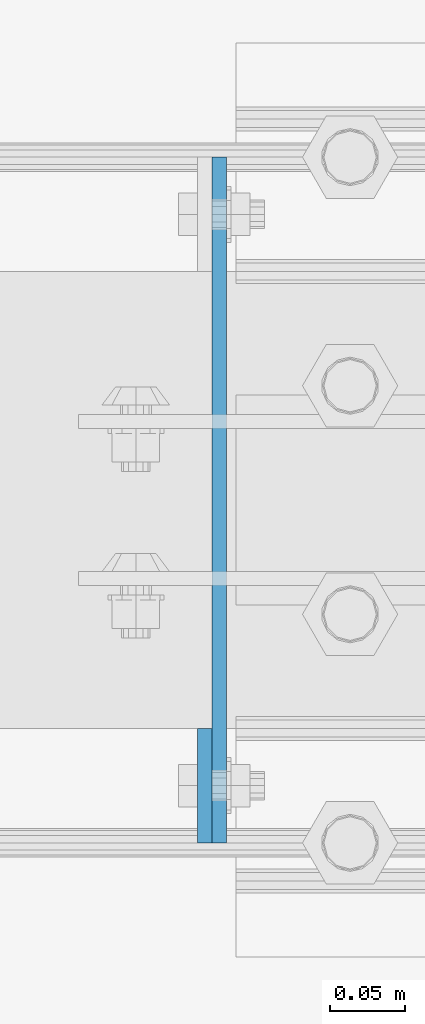
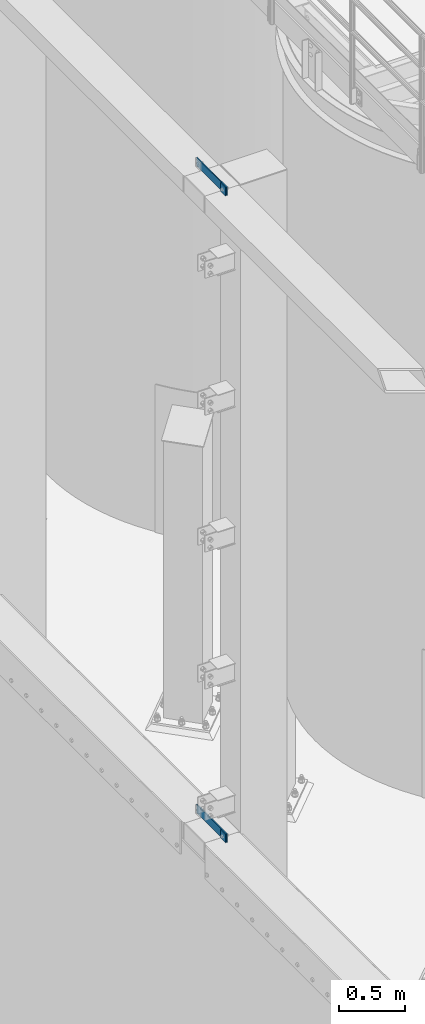
# One storey, part 1411 of 1876: 4 plates, 3 elements without a shape of their own.
"""IFC2X3 building model written with IfcOpenShell, lengths in millimetres."""

from ifc_helpers import new_model, si_unit, frame, origin_with_axes, place, context, subcontext, project, spatial, faceted_brep, material, type_object, element, aggregate, save


model = new_model("IFC2X3")

# Units and contexts
model_context = context("Model", 3, precision=1e-05, world=origin_with_axes())
body_context = subcontext(model_context, "Body", "Model", "MODEL_VIEW")
ifc_project = project(units=[si_unit("LENGTHUNIT", "METRE", prefix="MILLI"), si_unit("AREAUNIT", "SQUARE_METRE"), si_unit("VOLUMEUNIT", "CUBIC_METRE"), si_unit("MASSUNIT", "GRAM", prefix="KILO"), si_unit("TIMEUNIT", "SECOND"), si_unit("PLANEANGLEUNIT", "RADIAN"), si_unit("SOLIDANGLEUNIT", "STERADIAN"), si_unit("THERMODYNAMICTEMPERATUREUNIT", "DEGREE_CELSIUS"), si_unit("LUMINOUSINTENSITYUNIT", "LUMEN")], contexts=[model_context])

# Site, building, storey
site_placement = place(None, origin_with_axes())
site = spatial("IfcSite", under=ifc_project, at=site_placement, CompositionType="ELEMENT")
building_placement = place(site_placement, origin_with_axes())
building = spatial("IfcBuilding", under=site, at=building_placement, Name="Undefined", CompositionType="ELEMENT")
storey_placement = place(building_placement, origin_with_axes())
storey = spatial("IfcBuildingStorey", under=building, at=storey_placement, Name="Undefined", CompositionType="ELEMENT", Elevation=0.0)

# Assembly, plate
assembly_1_placement = place(storey_placement, origin_with_axes())
assembly_1 = element("IfcElementAssembly", 1, at=assembly_1_placement, inside=storey, Name="BEAM", AssemblyPlace="NOTDEFINED", PredefinedType="RIGID_FRAME")
ifc_material = material(Name="STEEL/A36")
plate_type = type_object("IfcPlateType", PredefinedType="NOTDEFINED")
plate_1_placement = place(assembly_1_placement, frame((-144.4625, -18237.2, 10667.9356518697), z_axis=(0.0, -1.0, 0.0), x_axis=(0.0, 0.0, 1.0)))
plate_1 = element("IfcPlate", 2, at=plate_1_placement, type_object=plate_type, material=ifc_material, Name="PLATE", context=body_context, shape_type="Brep", body=[
    faceted_brep([(0.0, -4.76249999999982, 0.0), (0.0643511861562729, -4.76249999999999, 76.1999969482422), (0.0643511861562729, 4.76249999999999, 76.1999969482422), (0.0, 4.76249999999982, 0.0), (76.2643508911133, -4.76249999999999, 76.1999969482422), (76.2643508911133, 4.76249999999999, 76.1999969482422), (76.2643508911133, -4.76249999999999, 0.0), (76.2643508911133, 4.76249999999999, 0.0)], [[[0, 1, 2, 3]], [[1, 4, 5, 2]], [[4, 6, 7, 5]], [[6, 0, 3, 7]], [[5, 7, 3, 2]], [[6, 4, 1, 0]]]),
])
aggregate(assembly_1, [plate_1])

assembly_2_placement = place(storey_placement, origin_with_axes())
assembly_2 = element("IfcElementAssembly", 3, at=assembly_2_placement, inside=storey, Name="COLUMN", AssemblyPlace="NOTDEFINED", PredefinedType="RIGID_FRAME")
plate_2_placement = place(assembly_2_placement, frame((-134.9375, -18313.4, 10744.2), z_axis=(0.0, 1.0, 0.0), x_axis=(0.0, 0.0, -1.0)))
plate_2 = element("IfcPlate", 4, at=plate_2_placement, type_object=plate_type, material=ifc_material, Name="PLATE", context=body_context, shape_type="Brep", body=[
    faceted_brep([(0.0, -4.76249999999982, 0.0), (0.0, -4.76250000000073, 457.200012207031), (0.0, 4.76250000000073, 457.200012207031), (0.0, 4.76249999999982, 0.0), (76.1999969482422, -4.76250000000073, 457.200012207031), (76.1999969482422, 4.76250000000073, 457.200012207031), (76.1999969482422, -4.76250000000073, 0.0), (76.1999969482422, 4.76250000000073, 0.0)], [[[0, 1, 2, 3]], [[1, 4, 5, 2]], [[4, 6, 7, 5]], [[6, 0, 3, 7]], [[5, 7, 3, 2]], [[6, 4, 1, 0]]]),
])

assembly_3_placement = place(storey_placement, origin_with_axes())
assembly_3 = element("IfcElementAssembly", 5, at=assembly_3_placement, inside=storey, Name="BEAM", AssemblyPlace="NOTDEFINED", PredefinedType="RIGID_FRAME")
plate_3_placement = place(assembly_3_placement, frame((-144.4625, -18237.2, 4673.53565186968), z_axis=(0.0, -1.0, 0.0), x_axis=(0.0, 0.0, 1.0)))
plate_3 = element("IfcPlate", 6, at=plate_3_placement, type_object=plate_type, material=ifc_material, Name="PLATE", context=body_context, shape_type="Brep", body=[
    faceted_brep([(0.0, -4.76249999999982, 0.0), (0.0643511861562729, -4.76249999999999, 76.1999969482422), (0.0643511861562729, 4.76249999999999, 76.1999969482422), (0.0, 4.76249999999982, 0.0), (76.2643508911133, -4.76249999999999, 76.1999969482422), (76.2643508911133, 4.76249999999999, 76.1999969482422), (76.2643508911133, -4.76249999999999, 0.0), (76.2643508911133, 4.76249999999999, 0.0)], [[[0, 1, 2, 3]], [[1, 4, 5, 2]], [[4, 6, 7, 5]], [[6, 0, 3, 7]], [[5, 7, 3, 2]], [[6, 4, 1, 0]]]),
])
aggregate(assembly_3, [plate_3])

# Plate
plate_4_placement = place(assembly_2_placement, frame((-134.9375, -18313.4, 4749.8), z_axis=(0.0, 1.0, 0.0), x_axis=(0.0, 0.0, -1.0)))
plate_4 = element("IfcPlate", 7, at=plate_4_placement, type_object=plate_type, material=ifc_material, Name="PLATE", context=body_context, shape_type="Brep", body=[
    faceted_brep([(0.0, -4.76249999999982, 0.0), (0.0, -4.76250000000073, 457.200012207031), (0.0, 4.76250000000073, 457.200012207031), (0.0, 4.76249999999982, 0.0), (76.1999969482422, -4.76250000000073, 457.200012207031), (76.1999969482422, 4.76250000000073, 457.200012207031), (76.1999969482422, -4.76250000000073, 0.0), (76.1999969482422, 4.76250000000073, 0.0)], [[[0, 1, 2, 3]], [[1, 4, 5, 2]], [[4, 6, 7, 5]], [[6, 0, 3, 7]], [[5, 7, 3, 2]], [[6, 4, 1, 0]]]),
])

aggregate(assembly_2, [plate_2, plate_4])

save(model, "model.ifc")
